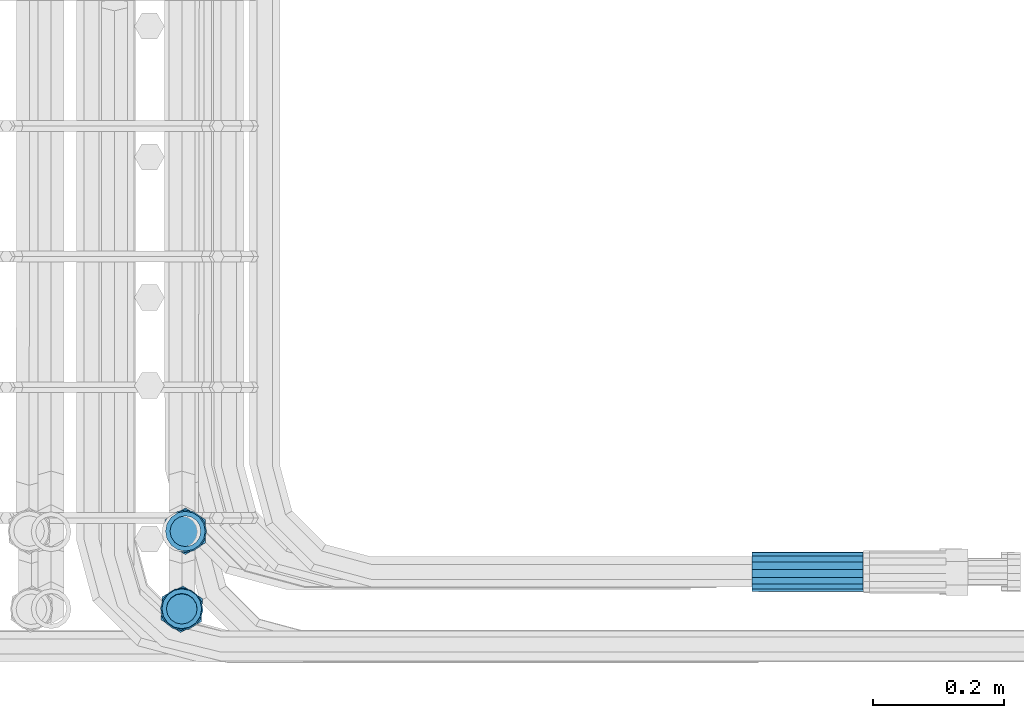
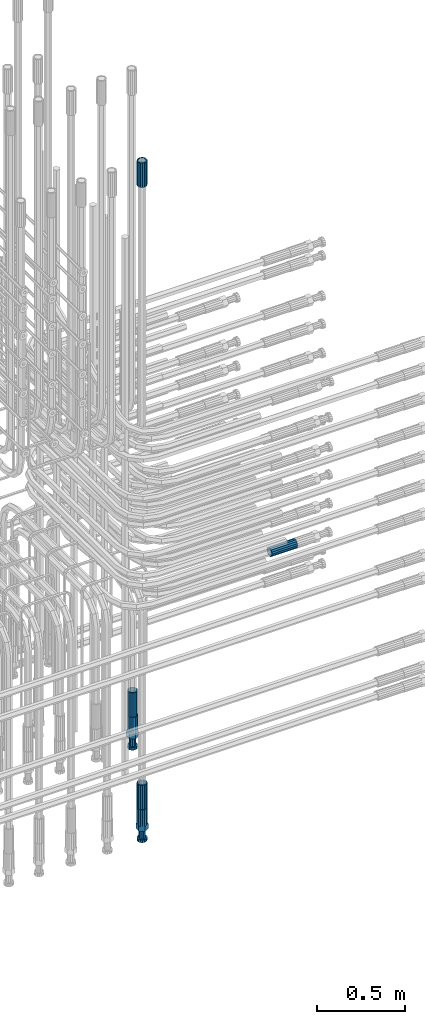
# One storey, part 100 of 177: 6 beams.
"""IFC2X3 building model written with IfcOpenShell, lengths in millimetres."""

from ifc_helpers import new_model, si_unit, frame, origin_with_axes, place, context, subcontext, project, spatial, faceted_brep, material, type_object, element, save


model = new_model("IFC2X3")

# Units and contexts
model_context_1 = context("Model", 3, precision=1e-05, world=origin_with_axes())
model_context_2 = context("Model", 3, precision=1e-05, world=origin_with_axes())
body_context = subcontext(model_context_2, "Body", "Model", "MODEL_VIEW")
ifc_project = project(units=[si_unit("LENGTHUNIT", "METRE", prefix="MILLI"), si_unit("AREAUNIT", "SQUARE_METRE"), si_unit("VOLUMEUNIT", "CUBIC_METRE"), si_unit("MASSUNIT", "GRAM", prefix="KILO"), si_unit("TIMEUNIT", "SECOND"), si_unit("PLANEANGLEUNIT", "RADIAN"), si_unit("SOLIDANGLEUNIT", "STERADIAN"), si_unit("THERMODYNAMICTEMPERATUREUNIT", "DEGREE_CELSIUS"), si_unit("LUMINOUSINTENSITYUNIT", "LUMEN")], contexts=[model_context_1])

# Site, building, storey
site_placement = place(None, origin_with_axes())
site = spatial("IfcSite", under=ifc_project, at=site_placement, CompositionType="ELEMENT")
building_placement = place(site_placement, origin_with_axes())
building = spatial("IfcBuilding", under=site, at=building_placement, Name="Undefined", CompositionType="ELEMENT")
storey_placement = place(building_placement, origin_with_axes())
storey = spatial("IfcBuildingStorey", under=building, at=storey_placement, Name="Undefined", CompositionType="ELEMENT", Elevation=0.0)

# Beams
ifc_material = material(Name="STEEL/S275")
beam_type_1 = type_object("IfcBeamType", PredefinedType="NOTDEFINED")
beam_1_placement = place(storey_placement, frame((2038709.03251517, 6205213.25328938, 19757.2481363619), z_axis=(0.00670106952218352, -0.100912931037137, -0.994872693371746), x_axis=(0.999977413914641, 0.000161830002033731, 0.00671903799942243)))
element("IfcBeam", 1, at=beam_1_placement, inside=storey, type_object=beam_type_1, material=ifc_material, Name="AG40N", context=body_context, shape_type="Brep", body=[
    faceted_brep([(0.0, -23.5000000001164, -9.31322574615479e-10), (0.0, -21.7111690140155, 8.99306066054851), (170.0, -21.7111690140155, 8.99306066054851), (170.0, -23.5, 0.0), (0.0, -16.6170093578839, 16.6170093575493), (170.0, -16.6170093578839, 16.6170093575493), (0.0, -8.99306066057943, 21.7111690137535), (170.0, -8.99306066057943, 21.7111690137535), (0.0, 1.16415321826935e-10, 23.5), (170.0, 0.0, 23.5), (0.0, 8.99306066057943, 21.7111690137535), (170.0, 8.99306066057943, 21.7111690137535), (0.0, 16.6170093578839, 16.6170093575493), (170.0, 16.6170093578839, 16.6170093575493), (0.0, 21.7111690140155, 8.99306066054851), (170.0, 21.7111690140155, 8.99306066054851), (0.0, 23.5000000001164, -9.31322574615479e-10), (170.0, 23.5, 0.0), (0.0, 21.7111690140155, -8.99306066054851), (170.0, 21.7111690140155, -8.99306066054851), (0.0, 16.6170093578839, -16.6170093575493), (170.0, 16.6170093578839, -16.6170093575493), (0.0, 8.99306066057943, -21.7111690137535), (170.0, 8.99306066057943, -21.7111690137535), (0.0, 1.16415321826935e-10, -23.5000000009313), (170.0, 0.0, -23.5), (0.0, -8.99306066057943, -21.7111690137535), (170.0, -8.99306066057943, -21.7111690137535), (0.0, -16.6170093578839, -16.6170093575493), (170.0, -16.6170093578839, -16.6170093575493), (0.0, -21.7111690140155, -8.99306066054851), (170.0, -21.7111690140155, -8.99306066054851), (0.0, -30.5, 0.0), (0.0, -28.1783257415937, -11.6718446873128), (170.0, -28.1783257415937, -11.6718446873128), (170.0, -30.5, 0.0), (0.0, -21.5667568261888, -21.5667568258941), (170.0, -21.5667568261888, -21.5667568258941), (0.0, -11.6718446871346, -28.1783257415518), (170.0, -11.6718446871346, -28.1783257415518), (0.0, 0.0, -30.5), (170.0, 0.0, -30.5), (0.0, 11.6718446871346, -28.1783257415518), (170.0, 11.6718446871346, -28.1783257415518), (0.0, 21.5667568261888, -21.5667568258941), (170.0, 21.5667568261888, -21.5667568258941), (0.0, 28.1783257415937, -11.6718446873128), (170.0, 28.1783257415937, -11.6718446873128), (0.0, 30.5, 0.0), (170.0, 30.5, 0.0), (0.0, 28.1783257415937, 11.6718446873128), (170.0, 28.1783257415937, 11.6718446873128), (0.0, 21.5667568261888, 21.5667568258941), (170.0, 21.5667568261888, 21.5667568258941), (0.0, 11.6718446871346, 28.1783257415518), (170.0, 11.6718446871346, 28.1783257415518), (0.0, 0.0, 30.5), (170.0, 0.0, 30.5), (0.0, -11.6718446871346, 28.1783257415518), (170.0, -11.6718446871346, 28.1783257415518), (0.0, -21.5667568261888, 21.5667568258941), (170.0, -21.5667568261888, 21.5667568258941), (0.0, -28.1783257415937, 11.6718446873128), (170.0, -28.1783257415937, 11.6718446873128)], [[[0, 1, 2, 3]], [[1, 4, 5, 2]], [[4, 6, 7, 5]], [[6, 8, 9, 7]], [[8, 10, 11, 9]], [[10, 12, 13, 11]], [[12, 14, 15, 13]], [[14, 16, 17, 15]], [[16, 18, 19, 17]], [[18, 20, 21, 19]], [[20, 22, 23, 21]], [[22, 24, 25, 23]], [[24, 26, 27, 25]], [[26, 28, 29, 27]], [[28, 30, 31, 29]], [[30, 0, 3, 31]], [[32, 33, 34, 35]], [[33, 36, 37, 34]], [[36, 38, 39, 37]], [[38, 40, 41, 39]], [[40, 42, 43, 41]], [[42, 44, 45, 43]], [[44, 46, 47, 45]], [[46, 48, 49, 47]], [[48, 50, 51, 49]], [[50, 52, 53, 51]], [[52, 54, 55, 53]], [[54, 56, 57, 55]], [[56, 58, 59, 57]], [[58, 60, 61, 59]], [[60, 62, 63, 61]], [[62, 32, 35, 63]], [[37, 39, 41, 43, 45, 47, 49, 51, 53, 55, 57, 59, 61, 63, 35, 34], [5, 7, 9, 11, 13, 15, 17, 19, 21, 23, 25, 27, 29, 31, 3, 2]], [[62, 60, 58, 56, 54, 52, 50, 48, 46, 44, 42, 40, 38, 36, 33, 32], [30, 28, 26, 24, 22, 20, 18, 16, 14, 12, 10, 8, 6, 4, 1, 0]]]),
])
beam_2_placement = place(storey_placement, frame((2037841.51022927, 6205275.04292825, 19061.465693403), z_axis=(-0.999999999997253, -1.99954956769953e-09, -2.344000607991e-06), x_axis=(2.88799980325754e-06, -3.12200144808909e-06, -0.999999999990956)))
element("IfcBeam", 2, at=beam_2_placement, inside=storey, type_object=beam_type_1, material=ifc_material, Name="AG40N", context=body_context, shape_type="Brep", body=[
    faceted_brep([(0.0, -23.5000000001164, -9.31322574615479e-10), (0.0, -21.7111690140155, 8.99306066054851), (170.0, -21.7111690140155, 8.99306066054851), (170.0, -23.5, 0.0), (0.0, -16.6170093578839, 16.6170093575493), (170.0, -16.6170093578839, 16.6170093575493), (0.0, -8.99306066057943, 21.7111690137535), (170.0, -8.99306066057943, 21.7111690137535), (0.0, 1.16415321826935e-10, 23.5), (170.0, 0.0, 23.5), (0.0, 8.99306066057943, 21.7111690137535), (170.0, 8.99306066057943, 21.7111690137535), (0.0, 16.6170093578839, 16.6170093575493), (170.0, 16.6170093578839, 16.6170093575493), (0.0, 21.7111690140155, 8.99306066054851), (170.0, 21.7111690140155, 8.99306066054851), (0.0, 23.5000000001164, -9.31322574615479e-10), (170.0, 23.5, 0.0), (0.0, 21.7111690140155, -8.99306066054851), (170.0, 21.7111690140155, -8.99306066054851), (0.0, 16.6170093578839, -16.6170093575493), (170.0, 16.6170093578839, -16.6170093575493), (0.0, 8.99306066057943, -21.7111690137535), (170.0, 8.99306066057943, -21.7111690137535), (0.0, 1.16415321826935e-10, -23.5000000009313), (170.0, 0.0, -23.5), (0.0, -8.99306066057943, -21.7111690137535), (170.0, -8.99306066057943, -21.7111690137535), (0.0, -16.6170093578839, -16.6170093575493), (170.0, -16.6170093578839, -16.6170093575493), (0.0, -21.7111690140155, -8.99306066054851), (170.0, -21.7111690140155, -8.99306066054851), (0.0, -30.5, 0.0), (0.0, -28.1783257415937, -11.6718446873128), (170.0, -28.1783257415937, -11.6718446873128), (170.0, -30.5, 0.0), (0.0, -21.5667568261888, -21.5667568258941), (170.0, -21.5667568261888, -21.5667568258941), (0.0, -11.6718446871346, -28.1783257415518), (170.0, -11.6718446871346, -28.1783257415518), (0.0, 0.0, -30.5), (170.0, 0.0, -30.5), (0.0, 11.6718446871346, -28.1783257415518), (170.0, 11.6718446871346, -28.1783257415518), (0.0, 21.5667568261888, -21.5667568258941), (170.0, 21.5667568261888, -21.5667568258941), (0.0, 28.1783257415937, -11.6718446873128), (170.0, 28.1783257415937, -11.6718446873128), (0.0, 30.5, 0.0), (170.0, 30.5, 0.0), (0.0, 28.1783257415937, 11.6718446873128), (170.0, 28.1783257415937, 11.6718446873128), (0.0, 21.5667568261888, 21.5667568258941), (170.0, 21.5667568261888, 21.5667568258941), (0.0, 11.6718446871346, 28.1783257415518), (170.0, 11.6718446871346, 28.1783257415518), (0.0, 0.0, 30.5), (170.0, 0.0, 30.5), (0.0, -11.6718446871346, 28.1783257415518), (170.0, -11.6718446871346, 28.1783257415518), (0.0, -21.5667568261888, 21.5667568258941), (170.0, -21.5667568261888, 21.5667568258941), (0.0, -28.1783257415937, 11.6718446873128), (170.0, -28.1783257415937, 11.6718446873128)], [[[0, 1, 2, 3]], [[1, 4, 5, 2]], [[4, 6, 7, 5]], [[6, 8, 9, 7]], [[8, 10, 11, 9]], [[10, 12, 13, 11]], [[12, 14, 15, 13]], [[14, 16, 17, 15]], [[16, 18, 19, 17]], [[18, 20, 21, 19]], [[20, 22, 23, 21]], [[22, 24, 25, 23]], [[24, 26, 27, 25]], [[26, 28, 29, 27]], [[28, 30, 31, 29]], [[30, 0, 3, 31]], [[32, 33, 34, 35]], [[33, 36, 37, 34]], [[36, 38, 39, 37]], [[38, 40, 41, 39]], [[40, 42, 43, 41]], [[42, 44, 45, 43]], [[44, 46, 47, 45]], [[46, 48, 49, 47]], [[48, 50, 51, 49]], [[50, 52, 53, 51]], [[52, 54, 55, 53]], [[54, 56, 57, 55]], [[56, 58, 59, 57]], [[58, 60, 61, 59]], [[60, 62, 63, 61]], [[62, 32, 35, 63]], [[37, 39, 41, 43, 45, 47, 49, 51, 53, 55, 57, 59, 61, 63, 35, 34], [5, 7, 9, 11, 13, 15, 17, 19, 21, 23, 25, 27, 29, 31, 3, 2]], [[62, 60, 58, 56, 54, 52, 50, 48, 46, 44, 42, 40, 38, 36, 33, 32], [30, 28, 26, 24, 22, 20, 18, 16, 14, 12, 10, 8, 6, 4, 1, 0]]]),
])
beam_3_placement = place(storey_placement, frame((2037835.99451629, 6205155.71214372, 18490.9763314081), z_axis=(-0.998629534815436, 0.0523359549902379, -3.09274809114867e-06), x_axis=(3.08299957658267e-06, -2.66999225447689e-07, -0.999999999995212)))
element("IfcBeam", 3, at=beam_3_placement, inside=storey, type_object=beam_type_1, material=ifc_material, Name="AG40N", context=body_context, shape_type="Brep", body=[
    faceted_brep([(0.0, -23.5000000001164, -9.31322574615479e-10), (0.0, -21.7111690140155, 8.99306066054851), (170.0, -21.7111690140155, 8.99306066054851), (170.0, -23.5, 0.0), (0.0, -16.6170093578839, 16.6170093575493), (170.0, -16.6170093578839, 16.6170093575493), (0.0, -8.99306066057943, 21.7111690137535), (170.0, -8.99306066057943, 21.7111690137535), (0.0, 1.16415321826935e-10, 23.5), (170.0, 0.0, 23.5), (0.0, 8.99306066057943, 21.7111690137535), (170.0, 8.99306066057943, 21.7111690137535), (0.0, 16.6170093578839, 16.6170093575493), (170.0, 16.6170093578839, 16.6170093575493), (0.0, 21.7111690140155, 8.99306066054851), (170.0, 21.7111690140155, 8.99306066054851), (0.0, 23.5000000001164, -9.31322574615479e-10), (170.0, 23.5, 0.0), (0.0, 21.7111690140155, -8.99306066054851), (170.0, 21.7111690140155, -8.99306066054851), (0.0, 16.6170093578839, -16.6170093575493), (170.0, 16.6170093578839, -16.6170093575493), (0.0, 8.99306066057943, -21.7111690137535), (170.0, 8.99306066057943, -21.7111690137535), (0.0, 1.16415321826935e-10, -23.5000000009313), (170.0, 0.0, -23.5), (0.0, -8.99306066057943, -21.7111690137535), (170.0, -8.99306066057943, -21.7111690137535), (0.0, -16.6170093578839, -16.6170093575493), (170.0, -16.6170093578839, -16.6170093575493), (0.0, -21.7111690140155, -8.99306066054851), (170.0, -21.7111690140155, -8.99306066054851), (0.0, -30.5, 0.0), (0.0, -28.1783257415937, -11.6718446873128), (170.0, -28.1783257415937, -11.6718446873128), (170.0, -30.5, 0.0), (0.0, -21.5667568261888, -21.5667568258941), (170.0, -21.5667568261888, -21.5667568258941), (0.0, -11.6718446871346, -28.1783257415518), (170.0, -11.6718446871346, -28.1783257415518), (0.0, 0.0, -30.5), (170.0, 0.0, -30.5), (0.0, 11.6718446871346, -28.1783257415518), (170.0, 11.6718446871346, -28.1783257415518), (0.0, 21.5667568261888, -21.5667568258941), (170.0, 21.5667568261888, -21.5667568258941), (0.0, 28.1783257415937, -11.6718446873128), (170.0, 28.1783257415937, -11.6718446873128), (0.0, 30.5, 0.0), (170.0, 30.5, 0.0), (0.0, 28.1783257415937, 11.6718446873128), (170.0, 28.1783257415937, 11.6718446873128), (0.0, 21.5667568261888, 21.5667568258941), (170.0, 21.5667568261888, 21.5667568258941), (0.0, 11.6718446871346, 28.1783257415518), (170.0, 11.6718446871346, 28.1783257415518), (0.0, 0.0, 30.5), (170.0, 0.0, 30.5), (0.0, -11.6718446871346, 28.1783257415518), (170.0, -11.6718446871346, 28.1783257415518), (0.0, -21.5667568261888, 21.5667568258941), (170.0, -21.5667568261888, 21.5667568258941), (0.0, -28.1783257415937, 11.6718446873128), (170.0, -28.1783257415937, 11.6718446873128)], [[[0, 1, 2, 3]], [[1, 4, 5, 2]], [[4, 6, 7, 5]], [[6, 8, 9, 7]], [[8, 10, 11, 9]], [[10, 12, 13, 11]], [[12, 14, 15, 13]], [[14, 16, 17, 15]], [[16, 18, 19, 17]], [[18, 20, 21, 19]], [[20, 22, 23, 21]], [[22, 24, 25, 23]], [[24, 26, 27, 25]], [[26, 28, 29, 27]], [[28, 30, 31, 29]], [[30, 0, 3, 31]], [[32, 33, 34, 35]], [[33, 36, 37, 34]], [[36, 38, 39, 37]], [[38, 40, 41, 39]], [[40, 42, 43, 41]], [[42, 44, 45, 43]], [[44, 46, 47, 45]], [[46, 48, 49, 47]], [[48, 50, 51, 49]], [[50, 52, 53, 51]], [[52, 54, 55, 53]], [[54, 56, 57, 55]], [[56, 58, 59, 57]], [[58, 60, 61, 59]], [[60, 62, 63, 61]], [[62, 32, 35, 63]], [[37, 39, 41, 43, 45, 47, 49, 51, 53, 55, 57, 59, 61, 63, 35, 34], [5, 7, 9, 11, 13, 15, 17, 19, 21, 23, 25, 27, 29, 31, 3, 2]], [[62, 60, 58, 56, 54, 52, 50, 48, 46, 44, 42, 40, 38, 36, 33, 32], [30, 28, 26, 24, 22, 20, 18, 16, 14, 12, 10, 8, 6, 4, 1, 0]]]),
])
beam_4_placement = place(storey_placement, frame((2037836.02583894, 6205156.40964939, 22659.9909079055), z_axis=(1.0, 0.0, 0.0), x_axis=(0.0, 0.0, 1.0)))
element("IfcBeam", 4, at=beam_4_placement, inside=storey, type_object=beam_type_1, material=ifc_material, Name="AG40N", context=body_context, shape_type="Brep", body=[
    faceted_brep([(0.0, -23.5000000001164, -9.31322574615479e-10), (0.0, -21.7111690140155, 8.99306066054851), (170.0, -21.7111690140155, 8.99306066054851), (170.0, -23.5, 0.0), (0.0, -16.6170093578839, 16.6170093575493), (170.0, -16.6170093578839, 16.6170093575493), (0.0, -8.99306066057943, 21.7111690137535), (170.0, -8.99306066057943, 21.7111690137535), (0.0, 1.16415321826935e-10, 23.5), (170.0, 0.0, 23.5), (0.0, 8.99306066057943, 21.7111690137535), (170.0, 8.99306066057943, 21.7111690137535), (0.0, 16.6170093578839, 16.6170093575493), (170.0, 16.6170093578839, 16.6170093575493), (0.0, 21.7111690140155, 8.99306066054851), (170.0, 21.7111690140155, 8.99306066054851), (0.0, 23.5000000001164, -9.31322574615479e-10), (170.0, 23.5, 0.0), (0.0, 21.7111690140155, -8.99306066054851), (170.0, 21.7111690140155, -8.99306066054851), (0.0, 16.6170093578839, -16.6170093575493), (170.0, 16.6170093578839, -16.6170093575493), (0.0, 8.99306066057943, -21.7111690137535), (170.0, 8.99306066057943, -21.7111690137535), (0.0, 1.16415321826935e-10, -23.5000000009313), (170.0, 0.0, -23.5), (0.0, -8.99306066057943, -21.7111690137535), (170.0, -8.99306066057943, -21.7111690137535), (0.0, -16.6170093578839, -16.6170093575493), (170.0, -16.6170093578839, -16.6170093575493), (0.0, -21.7111690140155, -8.99306066054851), (170.0, -21.7111690140155, -8.99306066054851), (0.0, -30.5, 0.0), (0.0, -28.1783257415937, -11.6718446873128), (170.0, -28.1783257415937, -11.6718446873128), (170.0, -30.5, 0.0), (0.0, -21.5667568261888, -21.5667568258941), (170.0, -21.5667568261888, -21.5667568258941), (0.0, -11.6718446871346, -28.1783257415518), (170.0, -11.6718446871346, -28.1783257415518), (0.0, 0.0, -30.5), (170.0, 0.0, -30.5), (0.0, 11.6718446871346, -28.1783257415518), (170.0, 11.6718446871346, -28.1783257415518), (0.0, 21.5667568261888, -21.5667568258941), (170.0, 21.5667568261888, -21.5667568258941), (0.0, 28.1783257415937, -11.6718446873128), (170.0, 28.1783257415937, -11.6718446873128), (0.0, 30.5, 0.0), (170.0, 30.5, 0.0), (0.0, 28.1783257415937, 11.6718446873128), (170.0, 28.1783257415937, 11.6718446873128), (0.0, 21.5667568261888, 21.5667568258941), (170.0, 21.5667568261888, 21.5667568258941), (0.0, 11.6718446871346, 28.1783257415518), (170.0, 11.6718446871346, 28.1783257415518), (0.0, 0.0, 30.5), (170.0, 0.0, 30.5), (0.0, -11.6718446871346, 28.1783257415518), (170.0, -11.6718446871346, 28.1783257415518), (0.0, -21.5667568261888, 21.5667568258941), (170.0, -21.5667568261888, 21.5667568258941), (0.0, -28.1783257415937, 11.6718446873128), (170.0, -28.1783257415937, 11.6718446873128)], [[[0, 1, 2, 3]], [[1, 4, 5, 2]], [[4, 6, 7, 5]], [[6, 8, 9, 7]], [[8, 10, 11, 9]], [[10, 12, 13, 11]], [[12, 14, 15, 13]], [[14, 16, 17, 15]], [[16, 18, 19, 17]], [[18, 20, 21, 19]], [[20, 22, 23, 21]], [[22, 24, 25, 23]], [[24, 26, 27, 25]], [[26, 28, 29, 27]], [[28, 30, 31, 29]], [[30, 0, 3, 31]], [[32, 33, 34, 35]], [[33, 36, 37, 34]], [[36, 38, 39, 37]], [[38, 40, 41, 39]], [[40, 42, 43, 41]], [[42, 44, 45, 43]], [[44, 46, 47, 45]], [[46, 48, 49, 47]], [[48, 50, 51, 49]], [[50, 52, 53, 51]], [[52, 54, 55, 53]], [[54, 56, 57, 55]], [[56, 58, 59, 57]], [[58, 60, 61, 59]], [[60, 62, 63, 61]], [[62, 32, 35, 63]], [[37, 39, 41, 43, 45, 47, 49, 51, 53, 55, 57, 59, 61, 63, 35, 34], [5, 7, 9, 11, 13, 15, 17, 19, 21, 23, 25, 27, 29, 31, 3, 2]], [[62, 60, 58, 56, 54, 52, 50, 48, 46, 44, 42, 40, 38, 36, 33, 32], [30, 28, 26, 24, 22, 20, 18, 16, 14, 12, 10, 8, 6, 4, 1, 0]]]),
])
beam_type_2 = type_object("IfcBeamType", Name="ROD65", PredefinedType="NOTDEFINED")
beam_5_placement = place(storey_placement, frame((2037841.51072025, 6205275.04239756, 18891.4656934041), z_axis=(-0.999999999997253, -1.99954956769953e-09, -2.344000607991e-06), x_axis=(2.88799980325754e-06, -3.12200144808909e-06, -0.999999999990956)))
element("IfcBeam", 5, at=beam_5_placement, inside=storey, type_object=beam_type_2, material=ifc_material, Name="AGB40", ObjectType="ROD65", context=body_context, shape_type="Brep", body=[
    faceted_brep([(117.0, 8.17543110251427, 30.873805644922), (117.0, 17.8250000001863, 30.873805644922), (117.0, 22.0056958701462, 23.6326279877685), (117.0, 12.4372115517035, 30.0260848065373), (117.0, -17.8250000001863, 30.873805644922), (150.200000000186, -17.8250000001863, 30.873805644922), (150.200000000186, 17.8250000001863, 30.873805644922), (117.0, -8.17543110251427, 30.873805644922), (117.0, -12.4372115517035, 30.0260848065373), (117.0, -22.0056958701462, 23.6326279877685), (117.0, -35.6500000003725, 0.0), (150.200000000186, -35.6500000003725, 0.0), (117.0, -30.8443150008097, 8.32369058486074), (117.0, -32.5, 0.0), (117.0, -30.8443150008097, -8.32369058462791), (117.0, -17.8250000001863, -30.873805644922), (150.200000000186, -17.8250000001863, -30.873805644922), (117.0, -22.0056958701462, -23.6326279877685), (117.0, -12.4372115517035, -30.0260848065373), (117.0, -8.17543110251427, -30.873805644922), (117.0, 17.8250000001863, -30.873805644922), (150.200000000186, 17.8250000001863, -30.873805644922), (117.0, 8.17543110251427, -30.873805644922), (117.0, 22.0056958701462, -23.6326279877685), (117.0, 12.4372115517035, -30.0260848065373), (117.0, 35.6500000003725, 0.0), (150.200000000186, 35.6500000003725, 0.0), (117.0, 30.8443150008097, -8.32369058486074), (117.0, 30.8443150008097, 8.32369058462791), (117.0, 32.5, 0.0), (0.0, -22.9809703892097, 22.9809703885621), (0.0, -30.0260848058388, 12.4372115518636), (117.0, -30.0260848067701, 12.4372115519363), (117.0, -22.9809703882784, 22.9809703885112), (-2.3283064365387e-10, 22.9809703892097, -22.9809703885639), (-4.65661287307739e-10, 30.0260848077014, -12.4372115518672), (117.0, 30.0260848067701, -12.4372115519363), (117.0, 22.9809703882784, -22.9809703885112), (-2.3283064365387e-10, -30.0260848067701, -12.4372115518672), (-2.3283064365387e-10, -22.9809703892097, -22.9809703885621), (117.0, -22.9809703882784, -22.9809703885112), (117.0, -30.0260848067701, -12.4372115519363), (-2.3283064365387e-10, -12.4372115507722, 30.0260848066137), (-2.3283064365387e-10, 9.31322574615479e-10, 32.4999999999982), (-2.3283064365387e-10, 12.4372115526348, 30.0260848066137), (0.0, 22.9809703892097, 22.9809703885621), (-2.3283064365387e-10, 30.0260848077014, 12.4372115518636), (-2.3283064365387e-10, 32.5, 0.0), (-2.3283064365387e-10, 12.4372115526348, -30.0260848066173), (-2.3283064365387e-10, 9.31322574615479e-10, -32.5), (-2.3283064365387e-10, -12.4372115517035, -30.0260848066173), (-4.65661287307739e-10, -32.4999999990687, -1.81898940354586e-12), (117.0, 22.9809703882784, 22.9809703885112), (117.0, 30.0260848067701, 12.4372115519363), (117.0, 0.0, -32.5), (117.0, 0.0, 32.5), (150.200000000186, 10.5, -18.1865334794857), (150.200000000186, 0.0, -21.0), (150.200000000186, -10.5, -18.1865334794857), (150.200000000186, -18.18653347902, -10.5), (150.200000000186, -21.0, 0.0), (150.200000000186, -18.18653347902, 10.5), (150.200000000186, -10.5, 18.1865334794857), (150.200000000186, 0.0, 21.0), (150.200000000186, 10.5, 18.1865334794857), (150.200000000186, 18.18653347902, 10.5), (150.200000000186, 21.0, 0.0), (150.200000000186, 18.18653347902, -10.5), (210.980000000447, -10.5, -18.1865334794857), (210.980000000447, 0.0, -21.0), (210.980000000447, -18.18653347902, -10.5), (210.980000000447, -21.0, 0.0), (210.980000000447, -18.18653347902, 10.5), (210.980000000447, -10.5, 18.1865334794857), (210.980000000447, 0.0, 21.0), (210.980000000447, 10.5, 18.1865334794857), (210.980000000447, 18.18653347902, 10.5), (210.980000000447, 21.0, 0.0), (210.980000000447, 18.18653347902, -10.5), (210.980000000447, 10.5, -18.1865334794857), (211.001368442696, -27.7269937992096, -11.491116326768), (211.003082550167, -21.2238094303757, -21.223815418547), (231.002518367059, -21.2131944671273, -21.2132004550658), (231.000804259587, -27.7163788359612, -11.4805013632867), (211.001368440451, -11.4911085031927, -27.7269970395137), (231.000804257343, -11.4804935399443, -27.7163820760325), (210.996487071217, -0.0106065049767494, -30.0106107392348), (230.995922888109, 8.45827162265778e-06, -29.9999957757536), (210.989181586672, 11.46989420522, -27.7269970329944), (230.988617403564, 11.4805091684684, -27.7163820695132), (210.980564180623, 21.2025914648548, -21.2238154064398), (230.979999997515, 21.2132064281031, -21.2132004429586), (210.971946775022, 27.7057703435421, -11.4911163107026), (230.971382591913, 27.7163853067905, -11.4805013472214), (210.96464129175, 29.9893808094785, -0.0106149562634528), (230.964077108642, 29.9999957727268, 7.21774995326996e-09), (210.959759924415, 27.7057638689876, 11.4698863970116), (230.959195741307, 27.7163788322359, 11.4805013604928), (210.958045816944, 21.2025795001537, 21.2025854887906), (230.957481633835, 21.213194463402, 21.2132004522718), (210.95975992666, 11.4698785729706, 27.7057671097573), (230.959195743551, 11.480493536219, 27.7163820732385), (210.964641295894, -0.010623425245285, 29.9893808094785), (230.964077112785, -8.46199691295624e-06, 29.9999957729597), (210.971946780439, -11.4911241354421, 27.705767103238), (230.97138259733, -11.4805091721937, 27.7163820667192), (210.980564186488, -21.2238213950768, 21.2025854766835), (230.980000003379, -21.2132064318284, 21.2132004401647), (210.989181592089, -27.7270002737641, 11.4698863809463), (230.988617408981, -27.7163853105158, 11.4805013444275), (210.996487075361, -30.0106107397005, -0.0106149734929204), (230.995922892253, -29.9999957764521, -1.00117176771164e-08)], [[[0, 1, 2, 3]], [[4, 5, 6, 1, 0, 7]], [[4, 7, 8, 9]], [[10, 11, 5, 4, 9, 12]], [[10, 12, 13, 14]], [[15, 16, 11, 10, 14, 17]], [[15, 17, 18, 19]], [[20, 21, 16, 15, 19, 22]], [[23, 20, 22, 24]], [[25, 26, 21, 20, 23, 27]], [[28, 25, 27, 29]], [[30, 31, 32, 33]], [[34, 35, 36, 37]], [[38, 39, 40, 41]], [[31, 30, 42, 43, 44, 45, 46, 47, 35, 34, 48, 49, 50, 39, 38, 51]], [[46, 45, 52, 53]], [[29, 47, 46, 53, 28]], [[27, 36, 35, 47, 29]], [[23, 37, 36, 27]], [[24, 48, 34, 37, 23]], [[22, 54, 49, 48, 24]], [[19, 54, 22]], [[18, 50, 49, 54, 19]], [[17, 40, 39, 50, 18]], [[14, 41, 40, 17]], [[13, 51, 38, 41, 14]], [[12, 32, 31, 51, 13]], [[9, 33, 32, 12]], [[8, 42, 30, 33, 9]], [[7, 55, 43, 42, 8]], [[0, 55, 7]], [[3, 44, 43, 55, 0]], [[2, 52, 45, 44, 3]], [[28, 53, 52, 2]], [[1, 6, 26, 25, 28, 2]], [[5, 11, 16, 21, 26, 6], [56, 57, 58, 59, 60, 61, 62, 63, 64, 65, 66, 67]], [[68, 58, 57, 69]], [[70, 59, 58, 68]], [[71, 60, 59, 70]], [[72, 61, 60, 71]], [[73, 62, 61, 72]], [[74, 63, 62, 73]], [[75, 64, 63, 74]], [[76, 65, 64, 75]], [[77, 66, 65, 76]], [[78, 67, 66, 77]], [[79, 56, 67, 78]], [[69, 57, 56, 79]], [[80, 81, 82, 83]], [[81, 84, 85, 82]], [[84, 86, 87, 85]], [[86, 88, 89, 87]], [[88, 90, 91, 89]], [[90, 92, 93, 91]], [[92, 94, 95, 93]], [[94, 96, 97, 95]], [[96, 98, 99, 97]], [[98, 100, 101, 99]], [[100, 102, 103, 101]], [[102, 104, 105, 103]], [[104, 106, 107, 105]], [[106, 108, 109, 107]], [[108, 110, 111, 109]], [[82, 85, 87, 89, 91, 93, 95, 97, 99, 101, 103, 105, 107, 109, 111, 83]], [[110, 80, 83, 111]], [[108, 106, 104, 102, 100, 98, 96, 94, 92, 90, 88, 86, 84, 81, 80, 110], [78, 77, 76, 75, 74, 73, 72, 71, 70, 68, 69, 79]]]),
])
beam_6_placement = place(storey_placement, frame((2037835.99504039, 6205155.71209828, 18320.9763314354), z_axis=(-0.998629534815436, 0.0523359549902379, -3.09274809114867e-06), x_axis=(3.08299957658267e-06, -2.66999225447689e-07, -0.999999999995212)))
element("IfcBeam", 6, at=beam_6_placement, inside=storey, type_object=beam_type_2, material=ifc_material, Name="AGB40", ObjectType="ROD65", context=body_context, shape_type="Brep", body=[
    faceted_brep([(117.0, 8.17543110251427, 30.873805644922), (117.0, 17.8250000001863, 30.873805644922), (117.0, 22.0056958701462, 23.6326279877685), (117.0, 12.4372115517035, 30.0260848065373), (117.0, -17.8250000001863, 30.873805644922), (150.200000000186, -17.8250000001863, 30.873805644922), (150.200000000186, 17.8250000001863, 30.873805644922), (117.0, -8.17543110251427, 30.873805644922), (117.0, -12.4372115517035, 30.0260848065373), (117.0, -22.0056958701462, 23.6326279877685), (117.0, -35.6500000003725, 0.0), (150.200000000186, -35.6500000003725, 0.0), (117.0, -30.8443150008097, 8.32369058486074), (117.0, -32.5, 0.0), (117.0, -30.8443150008097, -8.32369058462791), (117.0, -17.8250000001863, -30.873805644922), (150.200000000186, -17.8250000001863, -30.873805644922), (117.0, -22.0056958701462, -23.6326279877685), (117.0, -12.4372115517035, -30.0260848065373), (117.0, -8.17543110251427, -30.873805644922), (117.0, 17.8250000001863, -30.873805644922), (150.200000000186, 17.8250000001863, -30.873805644922), (117.0, 8.17543110251427, -30.873805644922), (117.0, 22.0056958701462, -23.6326279877685), (117.0, 12.4372115517035, -30.0260848065373), (117.0, 35.6500000003725, 0.0), (150.200000000186, 35.6500000003725, 0.0), (117.0, 30.8443150008097, -8.32369058486074), (117.0, 30.8443150008097, 8.32369058462791), (117.0, 32.5, 0.0), (0.0, -22.9809703892097, 22.9809703885621), (0.0, -30.0260848058388, 12.4372115518636), (117.0, -30.0260848067701, 12.4372115519363), (117.0, -22.9809703882784, 22.9809703885112), (-2.3283064365387e-10, 22.9809703892097, -22.9809703885639), (-4.65661287307739e-10, 30.0260848077014, -12.4372115518672), (117.0, 30.0260848067701, -12.4372115519363), (117.0, 22.9809703882784, -22.9809703885112), (-2.3283064365387e-10, -30.0260848067701, -12.4372115518672), (-2.3283064365387e-10, -22.9809703892097, -22.9809703885621), (117.0, -22.9809703882784, -22.9809703885112), (117.0, -30.0260848067701, -12.4372115519363), (-2.3283064365387e-10, -12.4372115507722, 30.0260848066137), (-2.3283064365387e-10, 9.31322574615479e-10, 32.4999999999982), (-2.3283064365387e-10, 12.4372115526348, 30.0260848066137), (0.0, 22.9809703892097, 22.9809703885621), (-2.3283064365387e-10, 30.0260848077014, 12.4372115518636), (-2.3283064365387e-10, 32.5, 0.0), (-2.3283064365387e-10, 12.4372115526348, -30.0260848066173), (-2.3283064365387e-10, 9.31322574615479e-10, -32.5), (-2.3283064365387e-10, -12.4372115517035, -30.0260848066173), (-4.65661287307739e-10, -32.4999999990687, -1.81898940354586e-12), (117.0, 22.9809703882784, 22.9809703885112), (117.0, 30.0260848067701, 12.4372115519363), (117.0, 0.0, -32.5), (117.0, 0.0, 32.5), (150.200000000186, 10.5, -18.1865334794857), (150.200000000186, 0.0, -21.0), (150.200000000186, -10.5, -18.1865334794857), (150.200000000186, -18.18653347902, -10.5), (150.200000000186, -21.0, 0.0), (150.200000000186, -18.18653347902, 10.5), (150.200000000186, -10.5, 18.1865334794857), (150.200000000186, 0.0, 21.0), (150.200000000186, 10.5, 18.1865334794857), (150.200000000186, 18.18653347902, 10.5), (150.200000000186, 21.0, 0.0), (150.200000000186, 18.18653347902, -10.5), (210.980000000447, -10.5, -18.1865334794857), (210.980000000447, 0.0, -21.0), (210.980000000447, -18.18653347902, -10.5), (210.980000000447, -21.0, 0.0), (210.980000000447, -18.18653347902, 10.5), (210.980000000447, -10.5, 18.1865334794857), (210.980000000447, 0.0, 21.0), (210.980000000447, 10.5, 18.1865334794857), (210.980000000447, 18.18653347902, 10.5), (210.980000000447, 21.0, 0.0), (210.980000000447, 18.18653347902, -10.5), (210.980000000447, 10.5, -18.1865334794857), (211.001368442696, -27.7269937992096, -11.491116326768), (211.003082550167, -21.2238094303757, -21.223815418547), (231.002518367059, -21.2131944671273, -21.2132004550658), (231.000804259587, -27.7163788359612, -11.4805013632867), (211.001368440451, -11.4911085031927, -27.7269970395137), (231.000804257343, -11.4804935399443, -27.7163820760325), (210.996487071217, -0.0106065049767494, -30.0106107392348), (230.995922888109, 8.45827162265778e-06, -29.9999957757536), (210.989181586672, 11.46989420522, -27.7269970329944), (230.988617403564, 11.4805091684684, -27.7163820695132), (210.980564180623, 21.2025914648548, -21.2238154064398), (230.979999997515, 21.2132064281031, -21.2132004429586), (210.971946775022, 27.7057703435421, -11.4911163107026), (230.971382591913, 27.7163853067905, -11.4805013472214), (210.96464129175, 29.9893808094785, -0.0106149562634528), (230.964077108642, 29.9999957727268, 7.21774995326996e-09), (210.959759924415, 27.7057638689876, 11.4698863970116), (230.959195741307, 27.7163788322359, 11.4805013604928), (210.958045816944, 21.2025795001537, 21.2025854887906), (230.957481633835, 21.213194463402, 21.2132004522718), (210.95975992666, 11.4698785729706, 27.7057671097573), (230.959195743551, 11.480493536219, 27.7163820732385), (210.964641295894, -0.010623425245285, 29.9893808094785), (230.964077112785, -8.46199691295624e-06, 29.9999957729597), (210.971946780439, -11.4911241354421, 27.705767103238), (230.97138259733, -11.4805091721937, 27.7163820667192), (210.980564186488, -21.2238213950768, 21.2025854766835), (230.980000003379, -21.2132064318284, 21.2132004401647), (210.989181592089, -27.7270002737641, 11.4698863809463), (230.988617408981, -27.7163853105158, 11.4805013444275), (210.996487075361, -30.0106107397005, -0.0106149734929204), (230.995922892253, -29.9999957764521, -1.00117176771164e-08)], [[[0, 1, 2, 3]], [[4, 5, 6, 1, 0, 7]], [[4, 7, 8, 9]], [[10, 11, 5, 4, 9, 12]], [[10, 12, 13, 14]], [[15, 16, 11, 10, 14, 17]], [[15, 17, 18, 19]], [[20, 21, 16, 15, 19, 22]], [[23, 20, 22, 24]], [[25, 26, 21, 20, 23, 27]], [[28, 25, 27, 29]], [[30, 31, 32, 33]], [[34, 35, 36, 37]], [[38, 39, 40, 41]], [[31, 30, 42, 43, 44, 45, 46, 47, 35, 34, 48, 49, 50, 39, 38, 51]], [[46, 45, 52, 53]], [[29, 47, 46, 53, 28]], [[27, 36, 35, 47, 29]], [[23, 37, 36, 27]], [[24, 48, 34, 37, 23]], [[22, 54, 49, 48, 24]], [[19, 54, 22]], [[18, 50, 49, 54, 19]], [[17, 40, 39, 50, 18]], [[14, 41, 40, 17]], [[13, 51, 38, 41, 14]], [[12, 32, 31, 51, 13]], [[9, 33, 32, 12]], [[8, 42, 30, 33, 9]], [[7, 55, 43, 42, 8]], [[0, 55, 7]], [[3, 44, 43, 55, 0]], [[2, 52, 45, 44, 3]], [[28, 53, 52, 2]], [[1, 6, 26, 25, 28, 2]], [[5, 11, 16, 21, 26, 6], [56, 57, 58, 59, 60, 61, 62, 63, 64, 65, 66, 67]], [[68, 58, 57, 69]], [[70, 59, 58, 68]], [[71, 60, 59, 70]], [[72, 61, 60, 71]], [[73, 62, 61, 72]], [[74, 63, 62, 73]], [[75, 64, 63, 74]], [[76, 65, 64, 75]], [[77, 66, 65, 76]], [[78, 67, 66, 77]], [[79, 56, 67, 78]], [[69, 57, 56, 79]], [[80, 81, 82, 83]], [[81, 84, 85, 82]], [[84, 86, 87, 85]], [[86, 88, 89, 87]], [[88, 90, 91, 89]], [[90, 92, 93, 91]], [[92, 94, 95, 93]], [[94, 96, 97, 95]], [[96, 98, 99, 97]], [[98, 100, 101, 99]], [[100, 102, 103, 101]], [[102, 104, 105, 103]], [[104, 106, 107, 105]], [[106, 108, 109, 107]], [[108, 110, 111, 109]], [[82, 85, 87, 89, 91, 93, 95, 97, 99, 101, 103, 105, 107, 109, 111, 83]], [[110, 80, 83, 111]], [[108, 106, 104, 102, 100, 98, 96, 94, 92, 90, 88, 86, 84, 81, 80, 110], [78, 77, 76, 75, 74, 73, 72, 71, 70, 68, 69, 79]]]),
])

save(model, "model.ifc")
